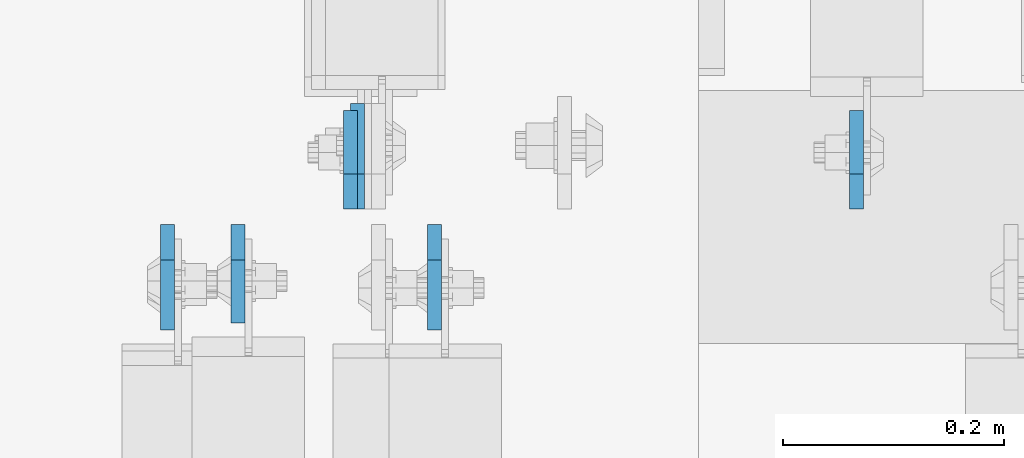
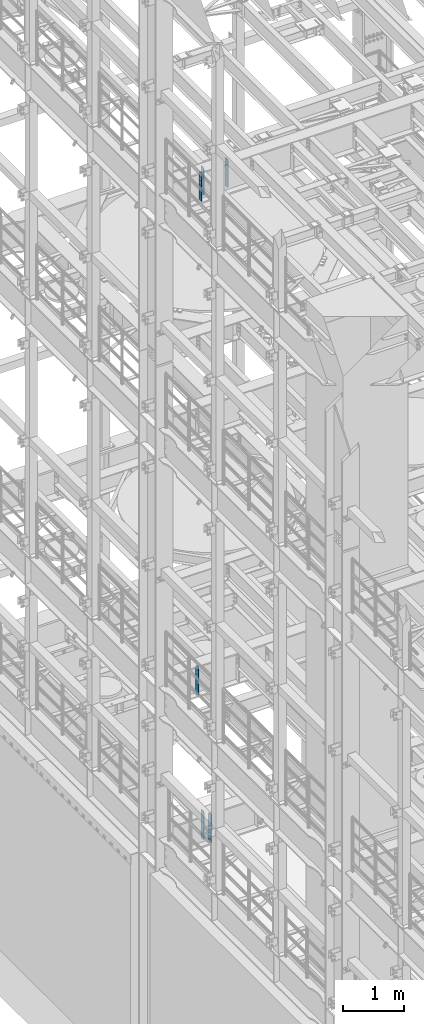
# One storey, part 1696 of 1876: 6 plates, 3 elements without a shape of their own.
"""IFC2X3 building model written with IfcOpenShell, lengths in millimetres."""

from ifc_helpers import new_model, si_unit, frame, origin_with_axes, place, context, subcontext, project, spatial, faceted_brep, material, type_object, element, aggregate, save


model = new_model("IFC2X3")

# Units and contexts
model_context = context("Model", 3, precision=1e-05, world=origin_with_axes())
body_context = subcontext(model_context, "Body", "Model", "MODEL_VIEW")
ifc_project = project(units=[si_unit("LENGTHUNIT", "METRE", prefix="MILLI"), si_unit("AREAUNIT", "SQUARE_METRE"), si_unit("VOLUMEUNIT", "CUBIC_METRE"), si_unit("MASSUNIT", "GRAM", prefix="KILO"), si_unit("TIMEUNIT", "SECOND"), si_unit("PLANEANGLEUNIT", "RADIAN"), si_unit("SOLIDANGLEUNIT", "STERADIAN"), si_unit("THERMODYNAMICTEMPERATUREUNIT", "DEGREE_CELSIUS"), si_unit("LUMINOUSINTENSITYUNIT", "LUMEN")], contexts=[model_context])

# Site, building, storey
site_placement = place(None, origin_with_axes())
site = spatial("IfcSite", under=ifc_project, at=site_placement, CompositionType="ELEMENT")
building_placement = place(site_placement, origin_with_axes())
building = spatial("IfcBuilding", under=site, at=building_placement, Name="Undefined", CompositionType="ELEMENT")
storey_placement = place(building_placement, origin_with_axes())
storey = spatial("IfcBuildingStorey", under=building, at=storey_placement, Name="Undefined", CompositionType="ELEMENT", Elevation=0.0)

# Assembly, plates
assembly_1_placement = place(storey_placement, origin_with_axes())
assembly_1 = element("IfcElementAssembly", 1, at=assembly_1_placement, inside=storey, Name="BEAM", AssemblyPlace="NOTDEFINED", PredefinedType="RIGID_FRAME")
ifc_material = material(Name="STEEL/A36")
plate_type_1 = type_object("IfcPlateType", PredefinedType="NOTDEFINED")
plate_1_placement = place(assembly_1_placement, frame((815.974999904632, 7612.85625, 17386.3), z_axis=(0.0, 0.0, 1.0), x_axis=(0.0, -1.0, 0.0)))
plate_1 = element("IfcPlate", 2, at=plate_1_placement, type_object=plate_type_1, material=ifc_material, Name="PLATE", context=body_context, shape_type="Brep", body=[
    faceted_brep([(0.0, -6.34999999999991, 31.75), (0.0, -6.34999999999991, 539.75), (0.0, 6.34999999999991, 539.75), (0.0, 6.34999999999991, 31.75), (31.75, -6.34999999999991, 571.5), (31.75, 6.34999999999991, 571.5), (88.9000015258789, -6.34999999999991, 571.5), (88.9000015258789, 6.34999999999991, 571.5), (88.9000015258789, -6.34999999999991, 0.0), (88.9000015258789, 6.34999999999991, 0.0), (31.75, -6.34999999999991, 0.0), (31.75, 6.34999999999991, 0.0)], [[[0, 1, 2, 3]], [[1, 4, 5, 2]], [[4, 6, 7, 5]], [[6, 8, 9, 7]], [[8, 10, 11, 9]], [[10, 0, 3, 11]], [[5, 7, 9, 11, 3, 2]], [[10, 8, 6, 4, 1, 0]]]),
])
plate_2_placement = place(assembly_1_placement, frame((1374.77499990463, 7627.14375, 17386.3), z_axis=(0.0, 0.0, 1.0), x_axis=(0.0, 1.0, 0.0)))
plate_2 = element("IfcPlate", 3, at=plate_2_placement, type_object=plate_type_1, material=ifc_material, Name="PLATE", context=body_context, shape_type="Brep", body=[
    faceted_brep([(0.0, -6.34999999999991, 31.75), (0.0, -6.34999999999991, 539.75), (0.0, 6.34999999999991, 539.75), (0.0, 6.34999999999991, 31.75), (31.75, -6.34999999999991, 571.5), (31.75, 6.34999999999991, 571.5), (88.9000015258789, -6.34999999999991, 571.5), (88.9000015258789, 6.34999999999991, 571.5), (88.9000015258789, -6.34999999999991, 0.0), (88.9000015258789, 6.34999999999991, 0.0), (31.75, -6.34999999999991, 0.0), (31.75, 6.34999999999991, 0.0)], [[[0, 1, 2, 3]], [[1, 4, 5, 2]], [[4, 6, 7, 5]], [[6, 8, 9, 7]], [[8, 10, 11, 9]], [[10, 0, 3, 11]], [[5, 7, 9, 11, 3, 2]], [[10, 8, 6, 4, 1, 0]]]),
])
plate_3_placement = place(assembly_1_placement, frame((917.574999904632, 7627.14375, 17386.3), z_axis=(0.0, 0.0, 1.0), x_axis=(0.0, 1.0, 0.0)))
plate_3 = element("IfcPlate", 4, at=plate_3_placement, type_object=plate_type_1, material=ifc_material, Name="PLATE", context=body_context, shape_type="Brep", body=[
    faceted_brep([(0.0, -6.34999999999991, 31.75), (0.0, -6.34999999999991, 539.75), (0.0, 6.34999999999991, 539.75), (0.0, 6.34999999999991, 31.75), (31.75, -6.34999999999991, 571.5), (31.75, 6.34999999999991, 571.5), (88.9000015258789, -6.34999999999991, 571.5), (88.9000015258789, 6.34999999999991, 571.5), (88.9000015258789, -6.34999999999991, 0.0), (88.9000015258789, 6.34999999999991, 0.0), (31.75, -6.34999999999991, 0.0), (31.75, 6.34999999999991, 0.0)], [[[0, 1, 2, 3]], [[1, 4, 5, 2]], [[4, 6, 7, 5]], [[6, 8, 9, 7]], [[8, 10, 11, 9]], [[10, 0, 3, 11]], [[5, 7, 9, 11, 3, 2]], [[10, 8, 6, 4, 1, 0]]]),
])
aggregate(assembly_1, [plate_1, plate_2, plate_3])

# Assembly, plate
assembly_2_placement = place(storey_placement, origin_with_axes())
assembly_2 = element("IfcElementAssembly", 5, at=assembly_2_placement, inside=storey, Name="BEAM", AssemblyPlace="NOTDEFINED", PredefinedType="RIGID_FRAME")
plate_type_2 = type_object("IfcPlateType", PredefinedType="NOTDEFINED")
plate_4_placement = place(assembly_2_placement, frame((752.474999904632, 7612.85625, 7558.0875), z_axis=(0.0, 0.0, 1.0), x_axis=(0.0, -1.0, 0.0)))
plate_4 = element("IfcPlate", 6, at=plate_4_placement, type_object=plate_type_2, material=ifc_material, Name="PLATE", context=body_context, shape_type="Brep", body=[
    faceted_brep([(0.0, -6.34999999999991, 31.75), (0.0, -6.35000000000036, 538.162475585938), (0.0, 6.35000000000036, 538.162475585938), (0.0, 6.34999999999991, 31.75), (31.75, -6.35000000000036, 569.912475585938), (31.75, 6.35000000000036, 569.912475585938), (95.25, -6.35000000000036, 569.912475585938), (95.25, 6.35000000000036, 569.912475585938), (95.25, -6.35000000000036, 0.0), (95.25, 6.35000000000036, 0.0), (31.75, -6.34999999999991, 0.0), (31.75, 6.34999999999991, 0.0)], [[[0, 1, 2, 3]], [[1, 4, 5, 2]], [[4, 6, 7, 5]], [[6, 8, 9, 7]], [[8, 10, 11, 9]], [[10, 0, 3, 11]], [[5, 7, 9, 11, 3, 2]], [[10, 8, 6, 4, 1, 0]]]),
])
aggregate(assembly_2, [plate_4])

# Assembly, plates
assembly_3_placement = place(storey_placement, origin_with_axes())
assembly_3 = element("IfcElementAssembly", 7, at=assembly_3_placement, inside=storey, Name="BEAM", AssemblyPlace="NOTDEFINED", PredefinedType="RIGID_FRAME")
plate_5_placement = place(assembly_3_placement, frame((993.775, 7612.85625, 4535.4875), z_axis=(0.0, 0.0, 1.0), x_axis=(0.0, -1.0, 0.0)))
plate_5 = element("IfcPlate", 8, at=plate_5_placement, type_object=plate_type_2, material=ifc_material, Name="PLATE", context=body_context, shape_type="Brep", body=[
    faceted_brep([(0.0, -6.34999999999991, 31.75), (0.0, -6.35000000000036, 538.162475585938), (0.0, 6.35000000000036, 538.162475585938), (0.0, 6.34999999999991, 31.75), (31.75, -6.35000000000036, 569.912475585938), (31.75, 6.35000000000036, 569.912475585938), (95.25, -6.35000000000036, 569.912475585938), (95.25, 6.35000000000036, 569.912475585938), (95.25, -6.35000000000036, 0.0), (95.25, 6.35000000000036, 0.0), (31.75, -6.34999999999991, 0.0), (31.75, 6.34999999999991, 0.0)], [[[0, 1, 2, 3]], [[1, 4, 5, 2]], [[4, 6, 7, 5]], [[6, 8, 9, 7]], [[8, 10, 11, 9]], [[10, 0, 3, 11]], [[5, 7, 9, 11, 3, 2]], [[10, 8, 6, 4, 1, 0]]]),
])
plate_6_placement = place(assembly_3_placement, frame((923.924999904633, 7627.14375, 4535.4875), z_axis=(0.0, 0.0, 1.0), x_axis=(0.0, 1.0, 0.0)))
plate_6 = element("IfcPlate", 9, at=plate_6_placement, type_object=plate_type_2, material=ifc_material, Name="PLATE", context=body_context, shape_type="Brep", body=[
    faceted_brep([(0.0, -6.34999999999991, 31.75), (0.0, -6.35000000000036, 538.162475585938), (0.0, 6.35000000000036, 538.162475585938), (0.0, 6.34999999999991, 31.75), (31.75, -6.35000000000036, 569.912475585938), (31.75, 6.35000000000036, 569.912475585938), (95.25, -6.35000000000036, 569.912475585938), (95.25, 6.35000000000036, 569.912475585938), (95.25, -6.35000000000036, 0.0), (95.25, 6.35000000000036, 0.0), (31.75, -6.34999999999991, 0.0), (31.75, 6.34999999999991, 0.0)], [[[0, 1, 2, 3]], [[1, 4, 5, 2]], [[4, 6, 7, 5]], [[6, 8, 9, 7]], [[8, 10, 11, 9]], [[10, 0, 3, 11]], [[5, 7, 9, 11, 3, 2]], [[10, 8, 6, 4, 1, 0]]]),
])
aggregate(assembly_3, [plate_5, plate_6])

save(model, "model.ifc")
